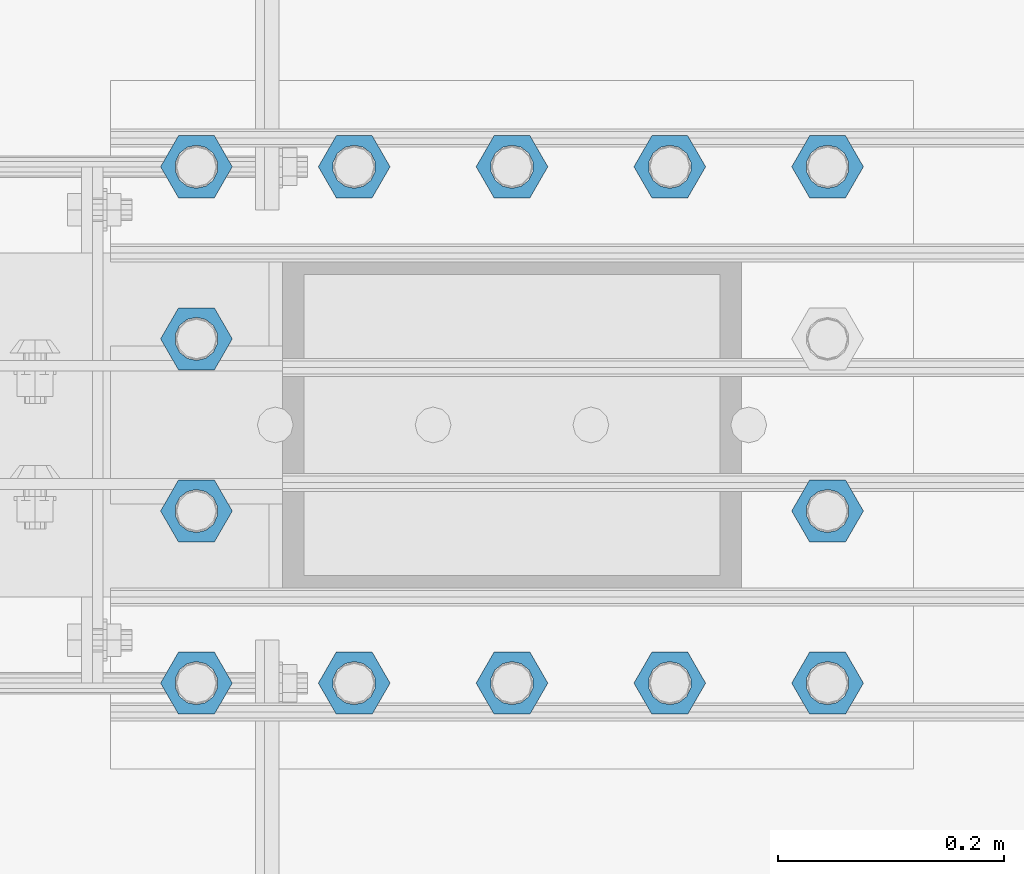
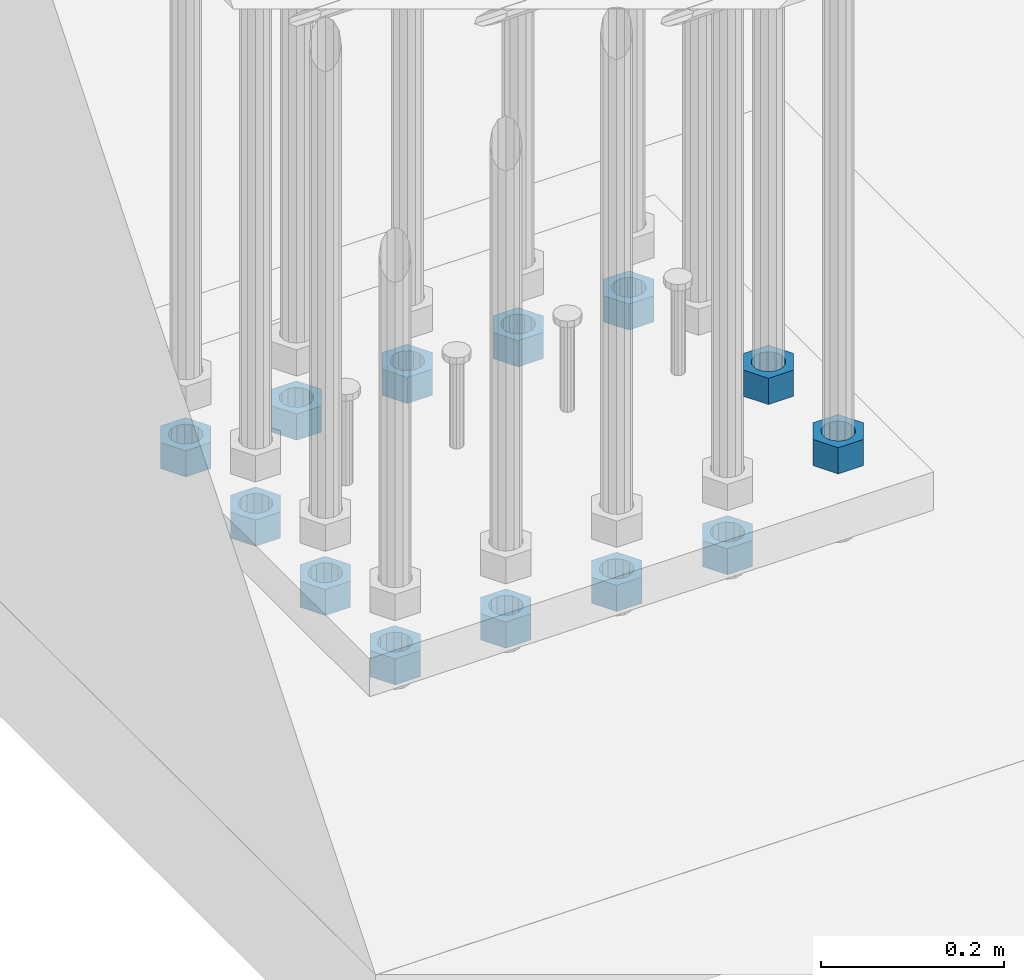
# One storey, part 1373 of 1876: 13 beams, 1 element without a shape of its own.
"""IFC2X3 building model written with IfcOpenShell, lengths in millimetres."""

from ifc_helpers import new_model, si_unit, frame, origin_with_axes, place, context, subcontext, project, spatial, faceted_brep, material, type_object, element, aggregate, save


model = new_model("IFC2X3")

# Units and contexts
model_context = context("Model", 3, precision=1e-05, world=origin_with_axes())
body_context = subcontext(model_context, "Body", "Model", "MODEL_VIEW")
ifc_project = project(units=[si_unit("LENGTHUNIT", "METRE", prefix="MILLI"), si_unit("AREAUNIT", "SQUARE_METRE"), si_unit("VOLUMEUNIT", "CUBIC_METRE"), si_unit("MASSUNIT", "GRAM", prefix="KILO"), si_unit("TIMEUNIT", "SECOND"), si_unit("PLANEANGLEUNIT", "RADIAN"), si_unit("SOLIDANGLEUNIT", "STERADIAN"), si_unit("THERMODYNAMICTEMPERATUREUNIT", "DEGREE_CELSIUS"), si_unit("LUMINOUSINTENSITYUNIT", "LUMEN")], contexts=[model_context])

# Site, building, storey
site_placement = place(None, origin_with_axes())
site = spatial("IfcSite", under=ifc_project, at=site_placement, CompositionType="ELEMENT")
building_placement = place(site_placement, origin_with_axes())
building = spatial("IfcBuilding", under=site, at=building_placement, Name="Undefined", CompositionType="ELEMENT")
storey_placement = place(building_placement, origin_with_axes())
storey = spatial("IfcBuildingStorey", under=building, at=storey_placement, Name="Undefined", CompositionType="ELEMENT", Elevation=0.0)

# Assembly, beams
assembly_placement = place(storey_placement, origin_with_axes())
assembly = element("IfcElementAssembly", 1, at=assembly_placement, inside=storey, Name="PLATE", AssemblyPlace="NOTDEFINED", PredefinedType="RIGID_FRAME")
ifc_material = material(Name="STEEL/A563")
beam_type = type_object("IfcBeamType", Name="1-3/8_HEAVY_HEX_NUT", PredefinedType="NOTDEFINED")
beam_1_placement = place(assembly_placement, frame((511.175003051757, -14503.399983724, -701.675000762938), z_axis=(0.0, -1.0, 0.0), x_axis=(0.0, 0.0, -1.0)))
beam_1 = element("IfcBeam", 2, at=beam_1_placement, type_object=beam_type, material=ifc_material, Name="NUT", ObjectType="1-3/8_HEAVY_HEX_NUT", context=body_context, shape_type="Brep", body=[
    faceted_brep([(0.0, -31.75, 0.0), (0.0, -15.8800001144409, -27.5), (34.925, -15.8800001144409, -27.5), (34.925, -31.75, 0.0), (0.0, 15.8800001144409, -27.5), (34.925, 15.8800001144409, -27.5), (0.0, 31.75, 0.0), (34.925, 31.75, 0.0), (0.0, 15.8800001144409, 27.5), (34.925, 15.8800001144409, 27.5), (0.0, -15.8800001144409, 27.5), (34.925, -15.8800001144409, 27.5), (0.0, 0.0, 19.0499999999993), (0.0, 8.2654848991624, 17.1634562461559), (34.925, 8.26548489916252, 17.163456246155), (34.925, 0.0, 19.0499992370605), (0.0, 14.8938891445259, 11.8774802497237), (34.925, 14.8938891445259, 11.8774802497246), (0.0, 18.5723759832526, 4.2390236220981), (34.925, 18.5723759832528, 4.23902362209628), (0.0, 18.5723759832526, -4.2390236220981), (34.925, 18.5723759832528, -4.23902362209628), (0.0, 14.8938891445259, -11.8774802497237), (34.925, 14.8938891445259, -11.8774802497246), (0.0, 8.2654848991624, -17.1634562461568), (34.925, 8.26548489916252, -17.163456246155), (0.0, 0.0, -19.05), (34.925, 0.0, -19.0499992370605), (0.0, -8.2654848991624, -17.1634562461559), (34.925, -8.26548489916252, -17.163456246155), (0.0, -14.8938891445259, -11.8774802497237), (34.925, -14.8938891445259, -11.8774802497246), (0.0, -18.5723759832526, -4.2390236220981), (34.925, -18.5723759832528, -4.23902362209628), (0.0, -18.5723759832526, 4.2390236220981), (34.925, -18.5723759832528, 4.23902362209628), (0.0, -14.8938891445259, 11.8774802497237), (34.925, -14.8938891445259, 11.8774802497246), (0.0, -8.2654848991624, 17.1634562461568), (34.925, -8.26548489916252, 17.163456246155)], [[[0, 1, 2, 3]], [[1, 4, 5, 2]], [[4, 6, 7, 5]], [[6, 8, 9, 7]], [[8, 10, 11, 9]], [[10, 0, 3, 11]], [[12, 13, 14, 15]], [[13, 16, 17, 14]], [[16, 18, 19, 17]], [[18, 20, 21, 19]], [[20, 22, 23, 21]], [[22, 24, 25, 23]], [[24, 26, 27, 25]], [[26, 28, 29, 27]], [[28, 30, 31, 29]], [[30, 32, 33, 31]], [[32, 34, 35, 33]], [[34, 36, 37, 35]], [[36, 38, 39, 37]], [[38, 12, 15, 39]], [[5, 7, 9, 11, 3, 2], [17, 19, 21, 23, 25, 27, 29, 31, 33, 35, 37, 39, 15, 14]], [[10, 8, 6, 4, 1, 0], [38, 36, 34, 32, 30, 28, 26, 24, 22, 20, 18, 16, 13, 12]]]),
])
beam_2_placement = place(assembly_placement, frame((511.175003051757, -14655.7999755859, -701.675000762938), z_axis=(0.0, -1.0, 0.0), x_axis=(0.0, 0.0, -1.0)))
beam_2 = element("IfcBeam", 3, at=beam_2_placement, type_object=beam_type, material=ifc_material, Name="NUT", ObjectType="1-3/8_HEAVY_HEX_NUT", context=body_context, shape_type="Brep", body=[
    faceted_brep([(0.0, -31.75, 0.0), (0.0, -15.8800001144409, -27.5), (34.925, -15.8800001144409, -27.5), (34.925, -31.75, 0.0), (0.0, 15.8800001144409, -27.5), (34.925, 15.8800001144409, -27.5), (0.0, 31.75, 0.0), (34.925, 31.75, 0.0), (0.0, 15.8800001144409, 27.5), (34.925, 15.8800001144409, 27.5), (0.0, -15.8800001144409, 27.5), (34.925, -15.8800001144409, 27.5), (0.0, 0.0, 19.0499999999993), (0.0, 8.2654848991624, 17.1634562461559), (34.925, 8.26548489916252, 17.163456246155), (34.925, 0.0, 19.0499992370605), (0.0, 14.8938891445259, 11.8774802497237), (34.925, 14.8938891445259, 11.8774802497246), (0.0, 18.5723759832526, 4.2390236220981), (34.925, 18.5723759832528, 4.23902362209628), (0.0, 18.5723759832526, -4.2390236220981), (34.925, 18.5723759832528, -4.23902362209628), (0.0, 14.8938891445259, -11.8774802497237), (34.925, 14.8938891445259, -11.8774802497246), (0.0, 8.2654848991624, -17.1634562461568), (34.925, 8.26548489916252, -17.163456246155), (0.0, 0.0, -19.05), (34.925, 0.0, -19.0499992370605), (0.0, -8.2654848991624, -17.1634562461559), (34.925, -8.26548489916252, -17.163456246155), (0.0, -14.8938891445259, -11.8774802497237), (34.925, -14.8938891445259, -11.8774802497246), (0.0, -18.5723759832526, -4.2390236220981), (34.925, -18.5723759832528, -4.23902362209628), (0.0, -18.5723759832526, 4.2390236220981), (34.925, -18.5723759832528, 4.23902362209628), (0.0, -14.8938891445259, 11.8774802497237), (34.925, -14.8938891445259, 11.8774802497246), (0.0, -8.2654848991624, 17.1634562461568), (34.925, -8.26548489916252, 17.163456246155)], [[[0, 1, 2, 3]], [[1, 4, 5, 2]], [[4, 6, 7, 5]], [[6, 8, 9, 7]], [[8, 10, 11, 9]], [[10, 0, 3, 11]], [[12, 13, 14, 15]], [[13, 16, 17, 14]], [[16, 18, 19, 17]], [[18, 20, 21, 19]], [[20, 22, 23, 21]], [[22, 24, 25, 23]], [[24, 26, 27, 25]], [[26, 28, 29, 27]], [[28, 30, 31, 29]], [[30, 32, 33, 31]], [[32, 34, 35, 33]], [[34, 36, 37, 35]], [[36, 38, 39, 37]], [[38, 12, 15, 39]], [[5, 7, 9, 11, 3, 2], [17, 19, 21, 23, 25, 27, 29, 31, 33, 35, 37, 39, 15, 14]], [[10, 8, 6, 4, 1, 0], [38, 36, 34, 32, 30, 28, 26, 24, 22, 20, 18, 16, 13, 12]]]),
])
beam_3_placement = place(assembly_placement, frame((371.474987792968, -14198.6, -787.400000000001), z_axis=(0.0, -1.0, 0.0), x_axis=(0.0, 0.0, -1.0)))
beam_3 = element("IfcBeam", 4, at=beam_3_placement, type_object=beam_type, material=ifc_material, Name="NUT", ObjectType="1-3/8_HEAVY_HEX_NUT", context=body_context, shape_type="Brep", body=[
    faceted_brep([(0.0, -31.75, 0.0), (0.0, -15.8800001144409, -27.5), (34.925, -15.8800001144409, -27.5), (34.925, -31.75, 0.0), (0.0, 15.8800001144409, -27.5), (34.925, 15.8800001144409, -27.5), (0.0, 31.75, 0.0), (34.925, 31.75, 0.0), (0.0, 15.8800001144409, 27.5), (34.925, 15.8800001144409, 27.5), (0.0, -15.8800001144409, 27.5), (34.925, -15.8800001144409, 27.5), (0.0, 0.0, 19.0499999999993), (0.0, 8.2654848991624, 17.1634562461559), (34.925, 8.26548489916252, 17.163456246155), (34.925, 0.0, 19.0499992370605), (0.0, 14.8938891445259, 11.8774802497237), (34.925, 14.8938891445259, 11.8774802497246), (0.0, 18.5723759832526, 4.2390236220981), (34.925, 18.5723759832528, 4.23902362209628), (0.0, 18.5723759832526, -4.2390236220981), (34.925, 18.5723759832528, -4.23902362209628), (0.0, 14.8938891445259, -11.8774802497237), (34.925, 14.8938891445259, -11.8774802497246), (0.0, 8.2654848991624, -17.1634562461568), (34.925, 8.26548489916252, -17.163456246155), (0.0, 0.0, -19.05), (34.925, 0.0, -19.0499992370605), (0.0, -8.2654848991624, -17.1634562461559), (34.925, -8.26548489916252, -17.163456246155), (0.0, -14.8938891445259, -11.8774802497237), (34.925, -14.8938891445259, -11.8774802497246), (0.0, -18.5723759832526, -4.2390236220981), (34.925, -18.5723759832528, -4.23902362209628), (0.0, -18.5723759832526, 4.2390236220981), (34.925, -18.5723759832528, 4.23902362209628), (0.0, -14.8938891445259, 11.8774802497237), (34.925, -14.8938891445259, 11.8774802497246), (0.0, -8.2654848991624, 17.1634562461568), (34.925, -8.26548489916252, 17.163456246155)], [[[0, 1, 2, 3]], [[1, 4, 5, 2]], [[4, 6, 7, 5]], [[6, 8, 9, 7]], [[8, 10, 11, 9]], [[10, 0, 3, 11]], [[12, 13, 14, 15]], [[13, 16, 17, 14]], [[16, 18, 19, 17]], [[18, 20, 21, 19]], [[20, 22, 23, 21]], [[22, 24, 25, 23]], [[24, 26, 27, 25]], [[26, 28, 29, 27]], [[28, 30, 31, 29]], [[30, 32, 33, 31]], [[32, 34, 35, 33]], [[34, 36, 37, 35]], [[36, 38, 39, 37]], [[38, 12, 15, 39]], [[5, 7, 9, 11, 3, 2], [17, 19, 21, 23, 25, 27, 29, 31, 33, 35, 37, 39, 15, 14]], [[10, 8, 6, 4, 1, 0], [38, 36, 34, 32, 30, 28, 26, 24, 22, 20, 18, 16, 13, 12]]]),
])
beam_4_placement = place(assembly_placement, frame((231.774987792968, -14198.6, -787.400000000001), z_axis=(0.0, -1.0, 0.0), x_axis=(0.0, 0.0, -1.0)))
beam_4 = element("IfcBeam", 5, at=beam_4_placement, type_object=beam_type, material=ifc_material, Name="NUT", ObjectType="1-3/8_HEAVY_HEX_NUT", context=body_context, shape_type="Brep", body=[
    faceted_brep([(0.0, -31.75, 0.0), (0.0, -15.8800001144409, -27.5), (34.925, -15.8800001144409, -27.5), (34.925, -31.75, 0.0), (0.0, 15.8800001144409, -27.5), (34.925, 15.8800001144409, -27.5), (0.0, 31.75, 0.0), (34.925, 31.75, 0.0), (0.0, 15.8800001144409, 27.5), (34.925, 15.8800001144409, 27.5), (0.0, -15.8800001144409, 27.5), (34.925, -15.8800001144409, 27.5), (0.0, 0.0, 19.0499999999993), (0.0, 8.2654848991624, 17.1634562461559), (34.925, 8.26548489916252, 17.163456246155), (34.925, 0.0, 19.0499992370605), (0.0, 14.8938891445259, 11.8774802497237), (34.925, 14.8938891445259, 11.8774802497246), (0.0, 18.5723759832526, 4.2390236220981), (34.925, 18.5723759832528, 4.23902362209628), (0.0, 18.5723759832526, -4.2390236220981), (34.925, 18.5723759832528, -4.23902362209628), (0.0, 14.8938891445259, -11.8774802497237), (34.925, 14.8938891445259, -11.8774802497246), (0.0, 8.2654848991624, -17.1634562461568), (34.925, 8.26548489916252, -17.163456246155), (0.0, 0.0, -19.05), (34.925, 0.0, -19.0499992370605), (0.0, -8.2654848991624, -17.1634562461559), (34.925, -8.26548489916252, -17.163456246155), (0.0, -14.8938891445259, -11.8774802497237), (34.925, -14.8938891445259, -11.8774802497246), (0.0, -18.5723759832526, -4.2390236220981), (34.925, -18.5723759832528, -4.23902362209628), (0.0, -18.5723759832526, 4.2390236220981), (34.925, -18.5723759832528, 4.23902362209628), (0.0, -14.8938891445259, 11.8774802497237), (34.925, -14.8938891445259, 11.8774802497246), (0.0, -8.2654848991624, 17.1634562461568), (34.925, -8.26548489916252, 17.163456246155)], [[[0, 1, 2, 3]], [[1, 4, 5, 2]], [[4, 6, 7, 5]], [[6, 8, 9, 7]], [[8, 10, 11, 9]], [[10, 0, 3, 11]], [[12, 13, 14, 15]], [[13, 16, 17, 14]], [[16, 18, 19, 17]], [[18, 20, 21, 19]], [[20, 22, 23, 21]], [[22, 24, 25, 23]], [[24, 26, 27, 25]], [[26, 28, 29, 27]], [[28, 30, 31, 29]], [[30, 32, 33, 31]], [[32, 34, 35, 33]], [[34, 36, 37, 35]], [[36, 38, 39, 37]], [[38, 12, 15, 39]], [[5, 7, 9, 11, 3, 2], [17, 19, 21, 23, 25, 27, 29, 31, 33, 35, 37, 39, 15, 14]], [[10, 8, 6, 4, 1, 0], [38, 36, 34, 32, 30, 28, 26, 24, 22, 20, 18, 16, 13, 12]]]),
])
beam_5_placement = place(assembly_placement, frame((92.0749877929677, -14198.6, -787.400000000001), z_axis=(0.0, -1.0, 0.0), x_axis=(0.0, 0.0, -1.0)))
beam_5 = element("IfcBeam", 6, at=beam_5_placement, type_object=beam_type, material=ifc_material, Name="NUT", ObjectType="1-3/8_HEAVY_HEX_NUT", context=body_context, shape_type="Brep", body=[
    faceted_brep([(0.0, -31.75, 0.0), (0.0, -15.8800001144409, -27.5), (34.925, -15.8800001144409, -27.5), (34.925, -31.75, 0.0), (0.0, 15.8800001144409, -27.5), (34.925, 15.8800001144409, -27.5), (0.0, 31.75, 0.0), (34.925, 31.75, 0.0), (0.0, 15.8800001144409, 27.5), (34.925, 15.8800001144409, 27.5), (0.0, -15.8800001144409, 27.5), (34.925, -15.8800001144409, 27.5), (0.0, 0.0, 19.0499999999993), (0.0, 8.2654848991624, 17.1634562461559), (34.925, 8.26548489916252, 17.163456246155), (34.925, 0.0, 19.0499992370605), (0.0, 14.8938891445259, 11.8774802497237), (34.925, 14.8938891445259, 11.8774802497246), (0.0, 18.5723759832526, 4.2390236220981), (34.925, 18.5723759832528, 4.23902362209628), (0.0, 18.5723759832526, -4.2390236220981), (34.925, 18.5723759832528, -4.23902362209628), (0.0, 14.8938891445259, -11.8774802497237), (34.925, 14.8938891445259, -11.8774802497246), (0.0, 8.2654848991624, -17.1634562461568), (34.925, 8.26548489916252, -17.163456246155), (0.0, 0.0, -19.05), (34.925, 0.0, -19.0499992370605), (0.0, -8.2654848991624, -17.1634562461559), (34.925, -8.26548489916252, -17.163456246155), (0.0, -14.8938891445259, -11.8774802497237), (34.925, -14.8938891445259, -11.8774802497246), (0.0, -18.5723759832526, -4.2390236220981), (34.925, -18.5723759832528, -4.23902362209628), (0.0, -18.5723759832526, 4.2390236220981), (34.925, -18.5723759832528, 4.23902362209628), (0.0, -14.8938891445259, 11.8774802497237), (34.925, -14.8938891445259, 11.8774802497246), (0.0, -8.2654848991624, 17.1634562461568), (34.925, -8.26548489916252, 17.163456246155)], [[[0, 1, 2, 3]], [[1, 4, 5, 2]], [[4, 6, 7, 5]], [[6, 8, 9, 7]], [[8, 10, 11, 9]], [[10, 0, 3, 11]], [[12, 13, 14, 15]], [[13, 16, 17, 14]], [[16, 18, 19, 17]], [[18, 20, 21, 19]], [[20, 22, 23, 21]], [[22, 24, 25, 23]], [[24, 26, 27, 25]], [[26, 28, 29, 27]], [[28, 30, 31, 29]], [[30, 32, 33, 31]], [[32, 34, 35, 33]], [[34, 36, 37, 35]], [[36, 38, 39, 37]], [[38, 12, 15, 39]], [[5, 7, 9, 11, 3, 2], [17, 19, 21, 23, 25, 27, 29, 31, 33, 35, 37, 39, 15, 14]], [[10, 8, 6, 4, 1, 0], [38, 36, 34, 32, 30, 28, 26, 24, 22, 20, 18, 16, 13, 12]]]),
])
beam_6_placement = place(assembly_placement, frame((-47.6250122070322, -14198.6, -787.400000000001), z_axis=(0.0, -1.0, 0.0), x_axis=(0.0, 0.0, -1.0)))
beam_6 = element("IfcBeam", 7, at=beam_6_placement, type_object=beam_type, material=ifc_material, Name="NUT", ObjectType="1-3/8_HEAVY_HEX_NUT", context=body_context, shape_type="Brep", body=[
    faceted_brep([(0.0, -31.75, 0.0), (0.0, -15.8800001144409, -27.5), (34.925, -15.8800001144409, -27.5), (34.925, -31.75, 0.0), (0.0, 15.8800001144409, -27.5), (34.925, 15.8800001144409, -27.5), (0.0, 31.75, 0.0), (34.925, 31.75, 0.0), (0.0, 15.8800001144409, 27.5), (34.925, 15.8800001144409, 27.5), (0.0, -15.8800001144409, 27.5), (34.925, -15.8800001144409, 27.5), (0.0, 0.0, 19.0499999999993), (0.0, 8.2654848991624, 17.1634562461559), (34.925, 8.26548489916252, 17.163456246155), (34.925, 0.0, 19.0499992370605), (0.0, 14.8938891445259, 11.8774802497237), (34.925, 14.8938891445259, 11.8774802497246), (0.0, 18.5723759832526, 4.2390236220981), (34.925, 18.5723759832528, 4.23902362209628), (0.0, 18.5723759832526, -4.2390236220981), (34.925, 18.5723759832528, -4.23902362209628), (0.0, 14.8938891445259, -11.8774802497237), (34.925, 14.8938891445259, -11.8774802497246), (0.0, 8.2654848991624, -17.1634562461568), (34.925, 8.26548489916252, -17.163456246155), (0.0, 0.0, -19.05), (34.925, 0.0, -19.0499992370605), (0.0, -8.2654848991624, -17.1634562461559), (34.925, -8.26548489916252, -17.163456246155), (0.0, -14.8938891445259, -11.8774802497237), (34.925, -14.8938891445259, -11.8774802497246), (0.0, -18.5723759832526, -4.2390236220981), (34.925, -18.5723759832528, -4.23902362209628), (0.0, -18.5723759832526, 4.2390236220981), (34.925, -18.5723759832528, 4.23902362209628), (0.0, -14.8938891445259, 11.8774802497237), (34.925, -14.8938891445259, 11.8774802497246), (0.0, -8.2654848991624, 17.1634562461568), (34.925, -8.26548489916252, 17.163456246155)], [[[0, 1, 2, 3]], [[1, 4, 5, 2]], [[4, 6, 7, 5]], [[6, 8, 9, 7]], [[8, 10, 11, 9]], [[10, 0, 3, 11]], [[12, 13, 14, 15]], [[13, 16, 17, 14]], [[16, 18, 19, 17]], [[18, 20, 21, 19]], [[20, 22, 23, 21]], [[22, 24, 25, 23]], [[24, 26, 27, 25]], [[26, 28, 29, 27]], [[28, 30, 31, 29]], [[30, 32, 33, 31]], [[32, 34, 35, 33]], [[34, 36, 37, 35]], [[36, 38, 39, 37]], [[38, 12, 15, 39]], [[5, 7, 9, 11, 3, 2], [17, 19, 21, 23, 25, 27, 29, 31, 33, 35, 37, 39, 15, 14]], [[10, 8, 6, 4, 1, 0], [38, 36, 34, 32, 30, 28, 26, 24, 22, 20, 18, 16, 13, 12]]]),
])
beam_7_placement = place(assembly_placement, frame((-47.6250122070322, -14350.999991862, -787.400000000001), z_axis=(0.0, -1.0, 0.0), x_axis=(0.0, 0.0, -1.0)))
beam_7 = element("IfcBeam", 8, at=beam_7_placement, type_object=beam_type, material=ifc_material, Name="NUT", ObjectType="1-3/8_HEAVY_HEX_NUT", context=body_context, shape_type="Brep", body=[
    faceted_brep([(0.0, -31.75, 0.0), (0.0, -15.8800001144409, -27.5), (34.925, -15.8800001144409, -27.5), (34.925, -31.75, 0.0), (0.0, 15.8800001144409, -27.5), (34.925, 15.8800001144409, -27.5), (0.0, 31.75, 0.0), (34.925, 31.75, 0.0), (0.0, 15.8800001144409, 27.5), (34.925, 15.8800001144409, 27.5), (0.0, -15.8800001144409, 27.5), (34.925, -15.8800001144409, 27.5), (0.0, 0.0, 19.0499999999993), (0.0, 8.2654848991624, 17.1634562461559), (34.925, 8.26548489916252, 17.163456246155), (34.925, 0.0, 19.0499992370605), (0.0, 14.8938891445259, 11.8774802497237), (34.925, 14.8938891445259, 11.8774802497246), (0.0, 18.5723759832526, 4.2390236220981), (34.925, 18.5723759832528, 4.23902362209628), (0.0, 18.5723759832526, -4.2390236220981), (34.925, 18.5723759832528, -4.23902362209628), (0.0, 14.8938891445259, -11.8774802497237), (34.925, 14.8938891445259, -11.8774802497246), (0.0, 8.2654848991624, -17.1634562461568), (34.925, 8.26548489916252, -17.163456246155), (0.0, 0.0, -19.05), (34.925, 0.0, -19.0499992370605), (0.0, -8.2654848991624, -17.1634562461559), (34.925, -8.26548489916252, -17.163456246155), (0.0, -14.8938891445259, -11.8774802497237), (34.925, -14.8938891445259, -11.8774802497246), (0.0, -18.5723759832526, -4.2390236220981), (34.925, -18.5723759832528, -4.23902362209628), (0.0, -18.5723759832526, 4.2390236220981), (34.925, -18.5723759832528, 4.23902362209628), (0.0, -14.8938891445259, 11.8774802497237), (34.925, -14.8938891445259, 11.8774802497246), (0.0, -8.2654848991624, 17.1634562461568), (34.925, -8.26548489916252, 17.163456246155)], [[[0, 1, 2, 3]], [[1, 4, 5, 2]], [[4, 6, 7, 5]], [[6, 8, 9, 7]], [[8, 10, 11, 9]], [[10, 0, 3, 11]], [[12, 13, 14, 15]], [[13, 16, 17, 14]], [[16, 18, 19, 17]], [[18, 20, 21, 19]], [[20, 22, 23, 21]], [[22, 24, 25, 23]], [[24, 26, 27, 25]], [[26, 28, 29, 27]], [[28, 30, 31, 29]], [[30, 32, 33, 31]], [[32, 34, 35, 33]], [[34, 36, 37, 35]], [[36, 38, 39, 37]], [[38, 12, 15, 39]], [[5, 7, 9, 11, 3, 2], [17, 19, 21, 23, 25, 27, 29, 31, 33, 35, 37, 39, 15, 14]], [[10, 8, 6, 4, 1, 0], [38, 36, 34, 32, 30, 28, 26, 24, 22, 20, 18, 16, 13, 12]]]),
])
beam_8_placement = place(assembly_placement, frame((-47.6250122070322, -14503.399983724, -787.400000000001), z_axis=(0.0, -1.0, 0.0), x_axis=(0.0, 0.0, -1.0)))
beam_8 = element("IfcBeam", 9, at=beam_8_placement, type_object=beam_type, material=ifc_material, Name="NUT", ObjectType="1-3/8_HEAVY_HEX_NUT", context=body_context, shape_type="Brep", body=[
    faceted_brep([(0.0, -31.75, 0.0), (0.0, -15.8800001144409, -27.5), (34.925, -15.8800001144409, -27.5), (34.925, -31.75, 0.0), (0.0, 15.8800001144409, -27.5), (34.925, 15.8800001144409, -27.5), (0.0, 31.75, 0.0), (34.925, 31.75, 0.0), (0.0, 15.8800001144409, 27.5), (34.925, 15.8800001144409, 27.5), (0.0, -15.8800001144409, 27.5), (34.925, -15.8800001144409, 27.5), (0.0, 0.0, 19.0499999999993), (0.0, 8.2654848991624, 17.1634562461559), (34.925, 8.26548489916252, 17.163456246155), (34.925, 0.0, 19.0499992370605), (0.0, 14.8938891445259, 11.8774802497237), (34.925, 14.8938891445259, 11.8774802497246), (0.0, 18.5723759832526, 4.2390236220981), (34.925, 18.5723759832528, 4.23902362209628), (0.0, 18.5723759832526, -4.2390236220981), (34.925, 18.5723759832528, -4.23902362209628), (0.0, 14.8938891445259, -11.8774802497237), (34.925, 14.8938891445259, -11.8774802497246), (0.0, 8.2654848991624, -17.1634562461568), (34.925, 8.26548489916252, -17.163456246155), (0.0, 0.0, -19.05), (34.925, 0.0, -19.0499992370605), (0.0, -8.2654848991624, -17.1634562461559), (34.925, -8.26548489916252, -17.163456246155), (0.0, -14.8938891445259, -11.8774802497237), (34.925, -14.8938891445259, -11.8774802497246), (0.0, -18.5723759832526, -4.2390236220981), (34.925, -18.5723759832528, -4.23902362209628), (0.0, -18.5723759832526, 4.2390236220981), (34.925, -18.5723759832528, 4.23902362209628), (0.0, -14.8938891445259, 11.8774802497237), (34.925, -14.8938891445259, 11.8774802497246), (0.0, -8.2654848991624, 17.1634562461568), (34.925, -8.26548489916252, 17.163456246155)], [[[0, 1, 2, 3]], [[1, 4, 5, 2]], [[4, 6, 7, 5]], [[6, 8, 9, 7]], [[8, 10, 11, 9]], [[10, 0, 3, 11]], [[12, 13, 14, 15]], [[13, 16, 17, 14]], [[16, 18, 19, 17]], [[18, 20, 21, 19]], [[20, 22, 23, 21]], [[22, 24, 25, 23]], [[24, 26, 27, 25]], [[26, 28, 29, 27]], [[28, 30, 31, 29]], [[30, 32, 33, 31]], [[32, 34, 35, 33]], [[34, 36, 37, 35]], [[36, 38, 39, 37]], [[38, 12, 15, 39]], [[5, 7, 9, 11, 3, 2], [17, 19, 21, 23, 25, 27, 29, 31, 33, 35, 37, 39, 15, 14]], [[10, 8, 6, 4, 1, 0], [38, 36, 34, 32, 30, 28, 26, 24, 22, 20, 18, 16, 13, 12]]]),
])
beam_9_placement = place(assembly_placement, frame((-47.6250122070322, -14655.7999755859, -787.400000000001), z_axis=(0.0, -1.0, 0.0), x_axis=(0.0, 0.0, -1.0)))
beam_9 = element("IfcBeam", 10, at=beam_9_placement, type_object=beam_type, material=ifc_material, Name="NUT", ObjectType="1-3/8_HEAVY_HEX_NUT", context=body_context, shape_type="Brep", body=[
    faceted_brep([(0.0, -31.75, 0.0), (0.0, -15.8800001144409, -27.5), (34.925, -15.8800001144409, -27.5), (34.925, -31.75, 0.0), (0.0, 15.8800001144409, -27.5), (34.925, 15.8800001144409, -27.5), (0.0, 31.75, 0.0), (34.925, 31.75, 0.0), (0.0, 15.8800001144409, 27.5), (34.925, 15.8800001144409, 27.5), (0.0, -15.8800001144409, 27.5), (34.925, -15.8800001144409, 27.5), (0.0, 0.0, 19.0499999999993), (0.0, 8.2654848991624, 17.1634562461559), (34.925, 8.26548489916252, 17.163456246155), (34.925, 0.0, 19.0499992370605), (0.0, 14.8938891445259, 11.8774802497237), (34.925, 14.8938891445259, 11.8774802497246), (0.0, 18.5723759832526, 4.2390236220981), (34.925, 18.5723759832528, 4.23902362209628), (0.0, 18.5723759832526, -4.2390236220981), (34.925, 18.5723759832528, -4.23902362209628), (0.0, 14.8938891445259, -11.8774802497237), (34.925, 14.8938891445259, -11.8774802497246), (0.0, 8.2654848991624, -17.1634562461568), (34.925, 8.26548489916252, -17.163456246155), (0.0, 0.0, -19.05), (34.925, 0.0, -19.0499992370605), (0.0, -8.2654848991624, -17.1634562461559), (34.925, -8.26548489916252, -17.163456246155), (0.0, -14.8938891445259, -11.8774802497237), (34.925, -14.8938891445259, -11.8774802497246), (0.0, -18.5723759832526, -4.2390236220981), (34.925, -18.5723759832528, -4.23902362209628), (0.0, -18.5723759832526, 4.2390236220981), (34.925, -18.5723759832528, 4.23902362209628), (0.0, -14.8938891445259, 11.8774802497237), (34.925, -14.8938891445259, 11.8774802497246), (0.0, -8.2654848991624, 17.1634562461568), (34.925, -8.26548489916252, 17.163456246155)], [[[0, 1, 2, 3]], [[1, 4, 5, 2]], [[4, 6, 7, 5]], [[6, 8, 9, 7]], [[8, 10, 11, 9]], [[10, 0, 3, 11]], [[12, 13, 14, 15]], [[13, 16, 17, 14]], [[16, 18, 19, 17]], [[18, 20, 21, 19]], [[20, 22, 23, 21]], [[22, 24, 25, 23]], [[24, 26, 27, 25]], [[26, 28, 29, 27]], [[28, 30, 31, 29]], [[30, 32, 33, 31]], [[32, 34, 35, 33]], [[34, 36, 37, 35]], [[36, 38, 39, 37]], [[38, 12, 15, 39]], [[5, 7, 9, 11, 3, 2], [17, 19, 21, 23, 25, 27, 29, 31, 33, 35, 37, 39, 15, 14]], [[10, 8, 6, 4, 1, 0], [38, 36, 34, 32, 30, 28, 26, 24, 22, 20, 18, 16, 13, 12]]]),
])
beam_10_placement = place(assembly_placement, frame((92.0749877929678, -14655.7999755859, -787.400000000001), z_axis=(0.0, -1.0, 0.0), x_axis=(0.0, 0.0, -1.0)))
beam_10 = element("IfcBeam", 11, at=beam_10_placement, type_object=beam_type, material=ifc_material, Name="NUT", ObjectType="1-3/8_HEAVY_HEX_NUT", context=body_context, shape_type="Brep", body=[
    faceted_brep([(0.0, -31.75, 0.0), (0.0, -15.8800001144409, -27.5), (34.925, -15.8800001144409, -27.5), (34.925, -31.75, 0.0), (0.0, 15.8800001144409, -27.5), (34.925, 15.8800001144409, -27.5), (0.0, 31.75, 0.0), (34.925, 31.75, 0.0), (0.0, 15.8800001144409, 27.5), (34.925, 15.8800001144409, 27.5), (0.0, -15.8800001144409, 27.5), (34.925, -15.8800001144409, 27.5), (0.0, 0.0, 19.0499999999993), (0.0, 8.2654848991624, 17.1634562461559), (34.925, 8.26548489916252, 17.163456246155), (34.925, 0.0, 19.0499992370605), (0.0, 14.8938891445259, 11.8774802497237), (34.925, 14.8938891445259, 11.8774802497246), (0.0, 18.5723759832526, 4.2390236220981), (34.925, 18.5723759832528, 4.23902362209628), (0.0, 18.5723759832526, -4.2390236220981), (34.925, 18.5723759832528, -4.23902362209628), (0.0, 14.8938891445259, -11.8774802497237), (34.925, 14.8938891445259, -11.8774802497246), (0.0, 8.2654848991624, -17.1634562461568), (34.925, 8.26548489916252, -17.163456246155), (0.0, 0.0, -19.05), (34.925, 0.0, -19.0499992370605), (0.0, -8.2654848991624, -17.1634562461559), (34.925, -8.26548489916252, -17.163456246155), (0.0, -14.8938891445259, -11.8774802497237), (34.925, -14.8938891445259, -11.8774802497246), (0.0, -18.5723759832526, -4.2390236220981), (34.925, -18.5723759832528, -4.23902362209628), (0.0, -18.5723759832526, 4.2390236220981), (34.925, -18.5723759832528, 4.23902362209628), (0.0, -14.8938891445259, 11.8774802497237), (34.925, -14.8938891445259, 11.8774802497246), (0.0, -8.2654848991624, 17.1634562461568), (34.925, -8.26548489916252, 17.163456246155)], [[[0, 1, 2, 3]], [[1, 4, 5, 2]], [[4, 6, 7, 5]], [[6, 8, 9, 7]], [[8, 10, 11, 9]], [[10, 0, 3, 11]], [[12, 13, 14, 15]], [[13, 16, 17, 14]], [[16, 18, 19, 17]], [[18, 20, 21, 19]], [[20, 22, 23, 21]], [[22, 24, 25, 23]], [[24, 26, 27, 25]], [[26, 28, 29, 27]], [[28, 30, 31, 29]], [[30, 32, 33, 31]], [[32, 34, 35, 33]], [[34, 36, 37, 35]], [[36, 38, 39, 37]], [[38, 12, 15, 39]], [[5, 7, 9, 11, 3, 2], [17, 19, 21, 23, 25, 27, 29, 31, 33, 35, 37, 39, 15, 14]], [[10, 8, 6, 4, 1, 0], [38, 36, 34, 32, 30, 28, 26, 24, 22, 20, 18, 16, 13, 12]]]),
])
beam_11_placement = place(assembly_placement, frame((231.774987792968, -14655.7999755859, -787.400000000001), z_axis=(0.0, -1.0, 0.0), x_axis=(0.0, 0.0, -1.0)))
beam_11 = element("IfcBeam", 12, at=beam_11_placement, type_object=beam_type, material=ifc_material, Name="NUT", ObjectType="1-3/8_HEAVY_HEX_NUT", context=body_context, shape_type="Brep", body=[
    faceted_brep([(0.0, -31.75, 0.0), (0.0, -15.8800001144409, -27.5), (34.925, -15.8800001144409, -27.5), (34.925, -31.75, 0.0), (0.0, 15.8800001144409, -27.5), (34.925, 15.8800001144409, -27.5), (0.0, 31.75, 0.0), (34.925, 31.75, 0.0), (0.0, 15.8800001144409, 27.5), (34.925, 15.8800001144409, 27.5), (0.0, -15.8800001144409, 27.5), (34.925, -15.8800001144409, 27.5), (0.0, 0.0, 19.0499999999993), (0.0, 8.2654848991624, 17.1634562461559), (34.925, 8.26548489916252, 17.163456246155), (34.925, 0.0, 19.0499992370605), (0.0, 14.8938891445259, 11.8774802497237), (34.925, 14.8938891445259, 11.8774802497246), (0.0, 18.5723759832526, 4.2390236220981), (34.925, 18.5723759832528, 4.23902362209628), (0.0, 18.5723759832526, -4.2390236220981), (34.925, 18.5723759832528, -4.23902362209628), (0.0, 14.8938891445259, -11.8774802497237), (34.925, 14.8938891445259, -11.8774802497246), (0.0, 8.2654848991624, -17.1634562461568), (34.925, 8.26548489916252, -17.163456246155), (0.0, 0.0, -19.05), (34.925, 0.0, -19.0499992370605), (0.0, -8.2654848991624, -17.1634562461559), (34.925, -8.26548489916252, -17.163456246155), (0.0, -14.8938891445259, -11.8774802497237), (34.925, -14.8938891445259, -11.8774802497246), (0.0, -18.5723759832526, -4.2390236220981), (34.925, -18.5723759832528, -4.23902362209628), (0.0, -18.5723759832526, 4.2390236220981), (34.925, -18.5723759832528, 4.23902362209628), (0.0, -14.8938891445259, 11.8774802497237), (34.925, -14.8938891445259, 11.8774802497246), (0.0, -8.2654848991624, 17.1634562461568), (34.925, -8.26548489916252, 17.163456246155)], [[[0, 1, 2, 3]], [[1, 4, 5, 2]], [[4, 6, 7, 5]], [[6, 8, 9, 7]], [[8, 10, 11, 9]], [[10, 0, 3, 11]], [[12, 13, 14, 15]], [[13, 16, 17, 14]], [[16, 18, 19, 17]], [[18, 20, 21, 19]], [[20, 22, 23, 21]], [[22, 24, 25, 23]], [[24, 26, 27, 25]], [[26, 28, 29, 27]], [[28, 30, 31, 29]], [[30, 32, 33, 31]], [[32, 34, 35, 33]], [[34, 36, 37, 35]], [[36, 38, 39, 37]], [[38, 12, 15, 39]], [[5, 7, 9, 11, 3, 2], [17, 19, 21, 23, 25, 27, 29, 31, 33, 35, 37, 39, 15, 14]], [[10, 8, 6, 4, 1, 0], [38, 36, 34, 32, 30, 28, 26, 24, 22, 20, 18, 16, 13, 12]]]),
])
beam_12_placement = place(assembly_placement, frame((371.474987792968, -14655.7999755859, -787.400000000001), z_axis=(0.0, -1.0, 0.0), x_axis=(0.0, 0.0, -1.0)))
beam_12 = element("IfcBeam", 13, at=beam_12_placement, type_object=beam_type, material=ifc_material, Name="NUT", ObjectType="1-3/8_HEAVY_HEX_NUT", context=body_context, shape_type="Brep", body=[
    faceted_brep([(0.0, -31.75, 0.0), (0.0, -15.8800001144409, -27.5), (34.925, -15.8800001144409, -27.5), (34.925, -31.75, 0.0), (0.0, 15.8800001144409, -27.5), (34.925, 15.8800001144409, -27.5), (0.0, 31.75, 0.0), (34.925, 31.75, 0.0), (0.0, 15.8800001144409, 27.5), (34.925, 15.8800001144409, 27.5), (0.0, -15.8800001144409, 27.5), (34.925, -15.8800001144409, 27.5), (0.0, 0.0, 19.0499999999993), (0.0, 8.2654848991624, 17.1634562461559), (34.925, 8.26548489916252, 17.163456246155), (34.925, 0.0, 19.0499992370605), (0.0, 14.8938891445259, 11.8774802497237), (34.925, 14.8938891445259, 11.8774802497246), (0.0, 18.5723759832526, 4.2390236220981), (34.925, 18.5723759832528, 4.23902362209628), (0.0, 18.5723759832526, -4.2390236220981), (34.925, 18.5723759832528, -4.23902362209628), (0.0, 14.8938891445259, -11.8774802497237), (34.925, 14.8938891445259, -11.8774802497246), (0.0, 8.2654848991624, -17.1634562461568), (34.925, 8.26548489916252, -17.163456246155), (0.0, 0.0, -19.05), (34.925, 0.0, -19.0499992370605), (0.0, -8.2654848991624, -17.1634562461559), (34.925, -8.26548489916252, -17.163456246155), (0.0, -14.8938891445259, -11.8774802497237), (34.925, -14.8938891445259, -11.8774802497246), (0.0, -18.5723759832526, -4.2390236220981), (34.925, -18.5723759832528, -4.23902362209628), (0.0, -18.5723759832526, 4.2390236220981), (34.925, -18.5723759832528, 4.23902362209628), (0.0, -14.8938891445259, 11.8774802497237), (34.925, -14.8938891445259, 11.8774802497246), (0.0, -8.2654848991624, 17.1634562461568), (34.925, -8.26548489916252, 17.163456246155)], [[[0, 1, 2, 3]], [[1, 4, 5, 2]], [[4, 6, 7, 5]], [[6, 8, 9, 7]], [[8, 10, 11, 9]], [[10, 0, 3, 11]], [[12, 13, 14, 15]], [[13, 16, 17, 14]], [[16, 18, 19, 17]], [[18, 20, 21, 19]], [[20, 22, 23, 21]], [[22, 24, 25, 23]], [[24, 26, 27, 25]], [[26, 28, 29, 27]], [[28, 30, 31, 29]], [[30, 32, 33, 31]], [[32, 34, 35, 33]], [[34, 36, 37, 35]], [[36, 38, 39, 37]], [[38, 12, 15, 39]], [[5, 7, 9, 11, 3, 2], [17, 19, 21, 23, 25, 27, 29, 31, 33, 35, 37, 39, 15, 14]], [[10, 8, 6, 4, 1, 0], [38, 36, 34, 32, 30, 28, 26, 24, 22, 20, 18, 16, 13, 12]]]),
])
beam_13_placement = place(assembly_placement, frame((511.174999999999, -14198.6, -787.400000000001), z_axis=(0.0, -1.0, 0.0), x_axis=(0.0, 0.0, -1.0)))
beam_13 = element("IfcBeam", 14, at=beam_13_placement, type_object=beam_type, material=ifc_material, Name="NUT", ObjectType="1-3/8_HEAVY_HEX_NUT", context=body_context, shape_type="Brep", body=[
    faceted_brep([(0.0, -31.75, 0.0), (0.0, -15.8800001144409, -27.5), (34.925, -15.8800001144409, -27.5), (34.925, -31.75, 0.0), (0.0, 15.8800001144409, -27.5), (34.925, 15.8800001144409, -27.5), (0.0, 31.75, 0.0), (34.925, 31.75, 0.0), (0.0, 15.8800001144409, 27.5), (34.925, 15.8800001144409, 27.5), (0.0, -15.8800001144409, 27.5), (34.925, -15.8800001144409, 27.5), (0.0, 0.0, 19.0499999999993), (0.0, 8.2654848991624, 17.1634562461559), (34.925, 8.26548489916252, 17.163456246155), (34.925, 0.0, 19.0499992370605), (0.0, 14.8938891445259, 11.8774802497237), (34.925, 14.8938891445259, 11.8774802497246), (0.0, 18.5723759832526, 4.2390236220981), (34.925, 18.5723759832528, 4.23902362209628), (0.0, 18.5723759832526, -4.2390236220981), (34.925, 18.5723759832528, -4.23902362209628), (0.0, 14.8938891445259, -11.8774802497237), (34.925, 14.8938891445259, -11.8774802497246), (0.0, 8.2654848991624, -17.1634562461568), (34.925, 8.26548489916252, -17.163456246155), (0.0, 0.0, -19.05), (34.925, 0.0, -19.0499992370605), (0.0, -8.2654848991624, -17.1634562461559), (34.925, -8.26548489916252, -17.163456246155), (0.0, -14.8938891445259, -11.8774802497237), (34.925, -14.8938891445259, -11.8774802497246), (0.0, -18.5723759832526, -4.2390236220981), (34.925, -18.5723759832528, -4.23902362209628), (0.0, -18.5723759832526, 4.2390236220981), (34.925, -18.5723759832528, 4.23902362209628), (0.0, -14.8938891445259, 11.8774802497237), (34.925, -14.8938891445259, 11.8774802497246), (0.0, -8.2654848991624, 17.1634562461568), (34.925, -8.26548489916252, 17.163456246155)], [[[0, 1, 2, 3]], [[1, 4, 5, 2]], [[4, 6, 7, 5]], [[6, 8, 9, 7]], [[8, 10, 11, 9]], [[10, 0, 3, 11]], [[12, 13, 14, 15]], [[13, 16, 17, 14]], [[16, 18, 19, 17]], [[18, 20, 21, 19]], [[20, 22, 23, 21]], [[22, 24, 25, 23]], [[24, 26, 27, 25]], [[26, 28, 29, 27]], [[28, 30, 31, 29]], [[30, 32, 33, 31]], [[32, 34, 35, 33]], [[34, 36, 37, 35]], [[36, 38, 39, 37]], [[38, 12, 15, 39]], [[5, 7, 9, 11, 3, 2], [17, 19, 21, 23, 25, 27, 29, 31, 33, 35, 37, 39, 15, 14]], [[10, 8, 6, 4, 1, 0], [38, 36, 34, 32, 30, 28, 26, 24, 22, 20, 18, 16, 13, 12]]]),
])
aggregate(assembly, [beam_1, beam_2, beam_3, beam_4, beam_5, beam_6, beam_7, beam_8, beam_9, beam_10, beam_11, beam_12, beam_13])

save(model, "model.ifc")
